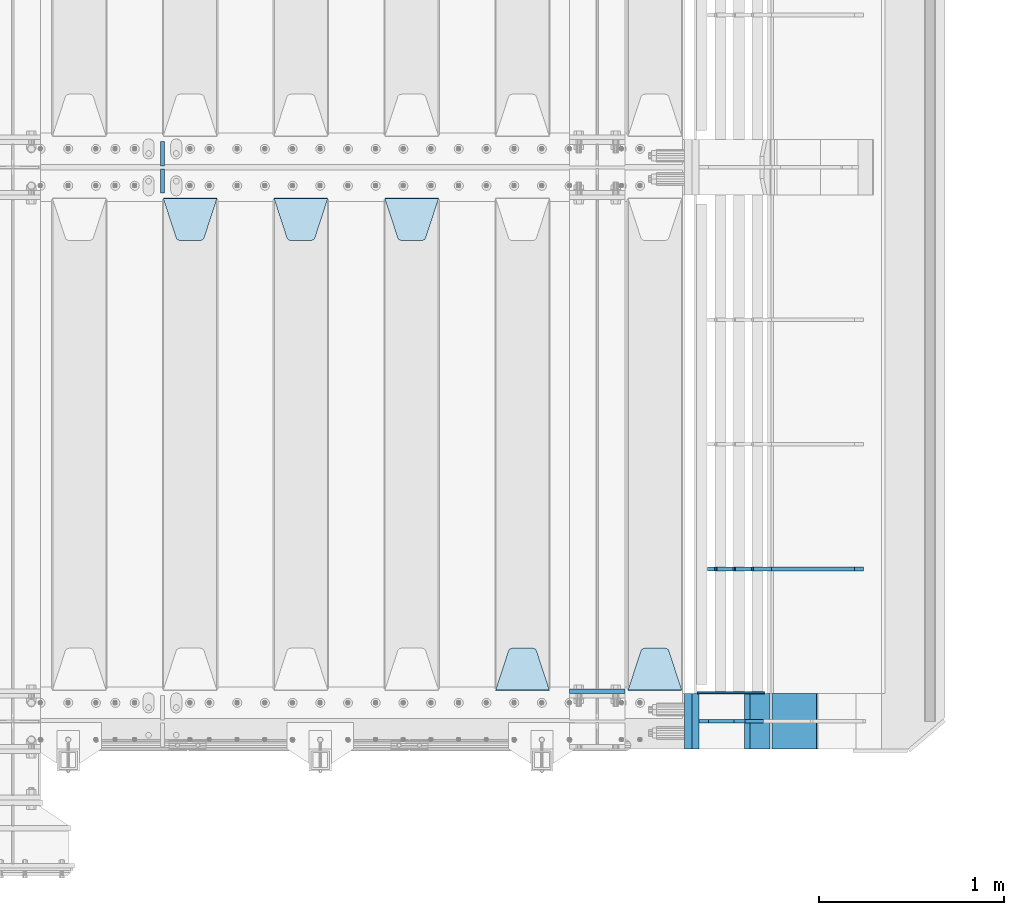
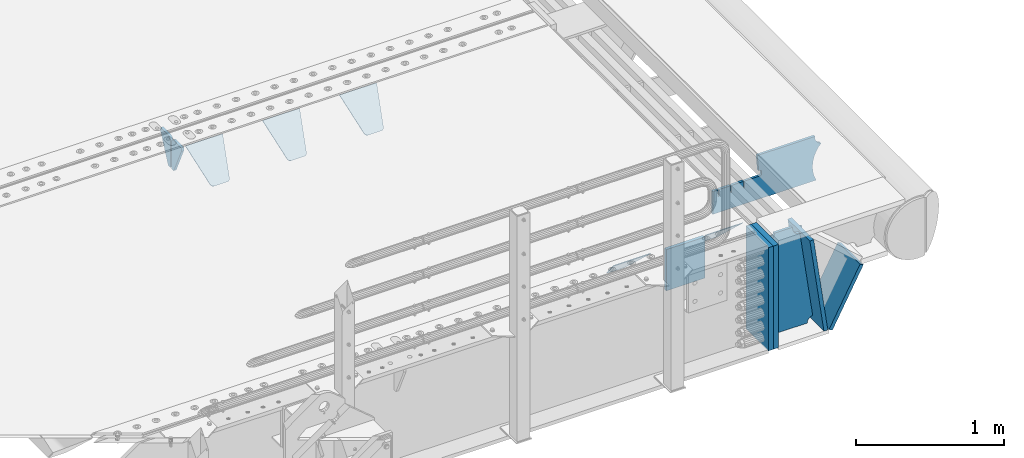
# One storey, part 202 of 240: 15 plates.
"""IFC2X3 building model written with IfcOpenShell, lengths in millimetres."""

from ifc_helpers import new_model, si_unit, frame, origin_with_axes, place, context, subcontext, project, spatial, faceted_brep, material, type_object, element, save


model = new_model("IFC2X3")

# Units and contexts
model_context = context("Model", 3, precision=1e-05, world=origin_with_axes())
body_context = subcontext(model_context, "Body", "Model", "MODEL_VIEW")
ifc_project = project(units=[si_unit("LENGTHUNIT", "METRE", prefix="MILLI"), si_unit("AREAUNIT", "SQUARE_METRE"), si_unit("VOLUMEUNIT", "CUBIC_METRE"), si_unit("MASSUNIT", "GRAM", prefix="KILO"), si_unit("TIMEUNIT", "SECOND"), si_unit("PLANEANGLEUNIT", "RADIAN"), si_unit("SOLIDANGLEUNIT", "STERADIAN"), si_unit("THERMODYNAMICTEMPERATUREUNIT", "DEGREE_CELSIUS"), si_unit("LUMINOUSINTENSITYUNIT", "LUMEN")], contexts=[model_context])

# Site, building, storey
site_placement = place(None, origin_with_axes())
site = spatial("IfcSite", under=ifc_project, at=site_placement, CompositionType="ELEMENT")
building_placement = place(site_placement, origin_with_axes())
building = spatial("IfcBuilding", under=site, at=building_placement, Name="Standard", CompositionType="ELEMENT")
storey_placement = place(building_placement, origin_with_axes())
storey = spatial("IfcBuildingStorey", under=building, at=storey_placement, Name="Undefined", CompositionType="ELEMENT", Elevation=0.0)

# Plates
ifc_material_1 = material(Name="STEEL/S355N")
plate_type_1 = type_object("IfcPlateType", PredefinedType="NOTDEFINED")
plate_1_placement = place(storey_placement, frame((55855.0, 24162.5, -340.000000000044), z_axis=(0.0, 0.0, 1.0), x_axis=(1.0, 0.0, 0.0)))
element("IfcPlate", 1, at=plate_1_placement, inside=storey, type_object=plate_type_1, material=ifc_material_1, context=body_context, shape_type="Brep", body=[
    faceted_brep([(0.0, -12.5, 0.0), (9.31322574615479e-10, -12.5, 340.0), (9.31322574615479e-10, 12.5, 340.0), (0.0, 12.5, 0.0), (300.0, -12.5, 340.0), (300.0, 12.5, 340.0), (300.0, -12.5, 0.0), (300.0, 12.5, 0.0)], [[[0, 1, 2, 3]], [[1, 4, 5, 2]], [[4, 6, 7, 5]], [[6, 0, 3, 7]], [[5, 7, 3, 2]], [[6, 4, 1, 0]]]),
])
plate_type_2 = type_object("IfcPlateType", PredefinedType="NOTDEFINED")
plate_2_placement = place(storey_placement, frame((56462.0, 24168.232233047, -1.76776695296758), z_axis=(0.0, 0.707106781186547, -0.707106781186548), x_axis=(-1.0, 0.0, 0.0)))
element("IfcPlate", 2, at=plate_2_placement, inside=storey, type_object=plate_type_2, material=ifc_material_1, context=body_context, shape_type="Brep", body=[
    faceted_brep([(0.0, -2.5, 0.0), (69.345504679477, -2.50000000000364, 300.171731424827), (69.345504679477, 2.49999999999636, 300.171731424827), (0.0, 2.5, 0.0), (70.927406119954, -2.50000000000364, 304.897442415397), (70.927406119954, 2.49999999999636, 304.897442415397), (73.3818627772271, -2.50000000000728, 309.234538108525), (73.3818627772271, 2.49999999999636, 309.234538108529), (76.6187032999587, -2.50000000000728, 313.023683126099), (76.6187032999587, 2.49999999999636, 313.023683126103), (80.5190132705029, -2.50000000000364, 316.125672595368), (80.5190132705029, 2.49999999999636, 316.125672595368), (84.9395038596849, -2.50000000000364, 318.426546230472), (84.9395038596849, 2.49999999999636, 318.426546230472), (89.7177759439219, -2.5, 319.841774983277), (89.7177759439219, 2.49999999999636, 319.841774983273), (94.6782862926484, -2.50000000000364, 320.319366455074), (94.6782862926484, 2.49999999999636, 320.319366455074), (195.321713707352, -2.50000000000364, 320.319366455074), (195.321713707352, 2.49999999999636, 320.319366455074), (200.282224056078, -2.50000000000364, 319.841774983273), (200.282224056078, 2.49999999999636, 319.841774983273), (205.060496140315, -2.50000000000364, 318.426546230472), (205.060496140315, 2.49999999999636, 318.426546230472), (209.480986729497, -2.50000000000364, 316.125672595368), (209.480986729497, 2.49999999999636, 316.125672595368), (213.381296700041, -2.50000000000728, 313.023683126099), (213.381296700041, 2.49999999999272, 313.023683126099), (216.618137222766, -2.50000000000364, 309.234538108522), (216.618137222766, 2.49999999999636, 309.234538108522), (219.072593880039, -2.50000000000364, 304.897442415397), (219.072593880039, 2.49999999999636, 304.897442415397), (220.654495320523, -2.50000000000364, 300.171731424827), (220.654495320523, 2.49999999999636, 300.171731424827), (290.0, -2.50000000000364, -3.63797880709171e-12), (290.0, 2.49999999999636, -3.63797880709171e-12)], [[[0, 1, 2, 3]], [[1, 4, 5, 2]], [[4, 6, 7, 5]], [[6, 8, 9, 7]], [[8, 10, 11, 9]], [[10, 12, 13, 11]], [[12, 14, 15, 13]], [[14, 16, 17, 15]], [[16, 18, 19, 17]], [[18, 20, 21, 19]], [[20, 22, 23, 21]], [[22, 24, 25, 23]], [[24, 26, 27, 25]], [[26, 28, 29, 27]], [[28, 30, 31, 29]], [[30, 32, 33, 31]], [[32, 34, 35, 33]], [[34, 0, 3, 35]], [[5, 7, 9, 11, 13, 15, 17, 19, 21, 23, 25, 27, 29, 31, 33, 35, 3, 2]], [[34, 32, 30, 28, 26, 24, 22, 20, 18, 16, 14, 12, 10, 8, 6, 4, 1, 0]]]),
])
plate_3_placement = place(storey_placement, frame((55745.0, 24168.232233047, -1.76776695296758), z_axis=(0.0, 0.707106781186547, -0.707106781186548), x_axis=(-1.0, 0.0, 0.0)))
element("IfcPlate", 3, at=plate_3_placement, inside=storey, type_object=plate_type_2, material=ifc_material_1, context=body_context, shape_type="Brep", body=[
    faceted_brep([(0.0, -2.5, 0.0), (69.345504679477, -2.50000000000364, 300.171731424827), (69.345504679477, 2.49999999999636, 300.171731424827), (0.0, 2.5, 0.0), (70.927406119954, -2.50000000000364, 304.897442415397), (70.927406119954, 2.49999999999636, 304.897442415397), (73.3818627772271, -2.50000000000728, 309.234538108525), (73.3818627772271, 2.49999999999636, 309.234538108529), (76.6187032999587, -2.50000000000728, 313.023683126099), (76.6187032999587, 2.49999999999636, 313.023683126103), (80.5190132705029, -2.50000000000364, 316.125672595368), (80.5190132705029, 2.49999999999636, 316.125672595368), (84.9395038596849, -2.50000000000364, 318.426546230472), (84.9395038596849, 2.49999999999636, 318.426546230472), (89.7177759439219, -2.5, 319.841774983277), (89.7177759439219, 2.49999999999636, 319.841774983273), (94.6782862926484, -2.50000000000364, 320.319366455074), (94.6782862926484, 2.49999999999636, 320.319366455074), (195.321713707352, -2.50000000000364, 320.319366455074), (195.321713707352, 2.49999999999636, 320.319366455074), (200.282224056078, -2.50000000000364, 319.841774983273), (200.282224056078, 2.49999999999636, 319.841774983273), (205.060496140315, -2.50000000000364, 318.426546230472), (205.060496140315, 2.49999999999636, 318.426546230472), (209.480986729497, -2.50000000000364, 316.125672595368), (209.480986729497, 2.49999999999636, 316.125672595368), (213.381296700041, -2.50000000000728, 313.023683126099), (213.381296700041, 2.49999999999272, 313.023683126099), (216.618137222766, -2.50000000000364, 309.234538108522), (216.618137222766, 2.49999999999636, 309.234538108522), (219.072593880039, -2.50000000000364, 304.897442415397), (219.072593880039, 2.49999999999636, 304.897442415397), (220.654495320523, -2.50000000000364, 300.171731424827), (220.654495320523, 2.49999999999636, 300.171731424827), (290.0, -2.50000000000364, -3.63797880709171e-12), (290.0, 2.49999999999636, -3.63797880709171e-12)], [[[0, 1, 2, 3]], [[1, 4, 5, 2]], [[4, 6, 7, 5]], [[6, 8, 9, 7]], [[8, 10, 11, 9]], [[10, 12, 13, 11]], [[12, 14, 15, 13]], [[14, 16, 17, 15]], [[16, 18, 19, 17]], [[18, 20, 21, 19]], [[20, 22, 23, 21]], [[22, 24, 25, 23]], [[24, 26, 27, 25]], [[26, 28, 29, 27]], [[28, 30, 31, 29]], [[30, 32, 33, 31]], [[32, 34, 35, 33]], [[34, 0, 3, 35]], [[5, 7, 9, 11, 13, 15, 17, 19, 21, 23, 25, 27, 29, 31, 33, 35, 3, 2]], [[34, 32, 30, 28, 26, 24, 22, 20, 18, 16, 14, 12, 10, 8, 6, 4, 1, 0]]]),
])
plate_4_placement = place(storey_placement, frame((54855.0, 26831.767766956, -1.76776695296758), z_axis=(0.0, -0.707106781186547, -0.707106781186548), x_axis=(1.0, 0.0, 0.0)))
element("IfcPlate", 4, at=plate_4_placement, inside=storey, type_object=plate_type_2, material=ifc_material_1, context=body_context, shape_type="Brep", body=[
    faceted_brep([(0.0, -2.5, 0.0), (69.345504679477, -2.50000000000364, 300.171731424827), (69.345504679477, 2.49999999999636, 300.171731424827), (0.0, 2.5, 0.0), (70.927406119954, -2.50000000000364, 304.897442415397), (70.927406119954, 2.49999999999636, 304.897442415397), (73.3818627772271, -2.50000000000728, 309.234538108525), (73.3818627772271, 2.49999999999636, 309.234538108529), (76.6187032999587, -2.50000000000728, 313.023683126099), (76.6187032999587, 2.49999999999636, 313.023683126103), (80.5190132705029, -2.50000000000364, 316.125672595368), (80.5190132705029, 2.49999999999636, 316.125672595368), (84.9395038596849, -2.50000000000364, 318.426546230472), (84.9395038596849, 2.49999999999636, 318.426546230472), (89.7177759439219, -2.5, 319.841774983277), (89.7177759439219, 2.49999999999636, 319.841774983273), (94.6782862926484, -2.50000000000364, 320.319366455074), (94.6782862926484, 2.49999999999636, 320.319366455074), (195.321713707352, -2.50000000000364, 320.319366455074), (195.321713707352, 2.49999999999636, 320.319366455074), (200.282224056078, -2.50000000000364, 319.841774983273), (200.282224056078, 2.49999999999636, 319.841774983273), (205.060496140315, -2.50000000000364, 318.426546230472), (205.060496140315, 2.49999999999636, 318.426546230472), (209.480986729497, -2.50000000000364, 316.125672595368), (209.480986729497, 2.49999999999636, 316.125672595368), (213.381296700041, -2.50000000000728, 313.023683126099), (213.381296700041, 2.49999999999272, 313.023683126099), (216.618137222766, -2.50000000000364, 309.234538108522), (216.618137222766, 2.49999999999636, 309.234538108522), (219.072593880039, -2.50000000000364, 304.897442415397), (219.072593880039, 2.49999999999636, 304.897442415397), (220.654495320523, -2.50000000000364, 300.171731424827), (220.654495320523, 2.49999999999636, 300.171731424827), (290.0, -2.50000000000364, -3.63797880709171e-12), (290.0, 2.49999999999636, -3.63797880709171e-12)], [[[0, 1, 2, 3]], [[1, 4, 5, 2]], [[4, 6, 7, 5]], [[6, 8, 9, 7]], [[8, 10, 11, 9]], [[10, 12, 13, 11]], [[12, 14, 15, 13]], [[14, 16, 17, 15]], [[16, 18, 19, 17]], [[18, 20, 21, 19]], [[20, 22, 23, 21]], [[22, 24, 25, 23]], [[24, 26, 27, 25]], [[26, 28, 29, 27]], [[28, 30, 31, 29]], [[30, 32, 33, 31]], [[32, 34, 35, 33]], [[34, 0, 3, 35]], [[5, 7, 9, 11, 13, 15, 17, 19, 21, 23, 25, 27, 29, 31, 33, 35, 3, 2]], [[34, 32, 30, 28, 26, 24, 22, 20, 18, 16, 14, 12, 10, 8, 6, 4, 1, 0]]]),
])
plate_5_placement = place(storey_placement, frame((54255.0, 26831.767766956, -1.76776695296758), z_axis=(0.0, -0.707106781186547, -0.707106781186548), x_axis=(1.0, 0.0, 0.0)))
element("IfcPlate", 5, at=plate_5_placement, inside=storey, type_object=plate_type_2, material=ifc_material_1, context=body_context, shape_type="Brep", body=[
    faceted_brep([(0.0, -2.5, 0.0), (69.345504679477, -2.50000000000364, 300.171731424827), (69.345504679477, 2.49999999999636, 300.171731424827), (0.0, 2.5, 0.0), (70.927406119954, -2.50000000000364, 304.897442415397), (70.927406119954, 2.49999999999636, 304.897442415397), (73.3818627772271, -2.50000000000728, 309.234538108525), (73.3818627772271, 2.49999999999636, 309.234538108529), (76.6187032999587, -2.50000000000728, 313.023683126099), (76.6187032999587, 2.49999999999636, 313.023683126103), (80.5190132705029, -2.50000000000364, 316.125672595368), (80.5190132705029, 2.49999999999636, 316.125672595368), (84.9395038596849, -2.50000000000364, 318.426546230472), (84.9395038596849, 2.49999999999636, 318.426546230472), (89.7177759439219, -2.5, 319.841774983277), (89.7177759439219, 2.49999999999636, 319.841774983273), (94.6782862926484, -2.50000000000364, 320.319366455074), (94.6782862926484, 2.49999999999636, 320.319366455074), (195.321713707352, -2.50000000000364, 320.319366455074), (195.321713707352, 2.49999999999636, 320.319366455074), (200.282224056078, -2.50000000000364, 319.841774983273), (200.282224056078, 2.49999999999636, 319.841774983273), (205.060496140315, -2.50000000000364, 318.426546230472), (205.060496140315, 2.49999999999636, 318.426546230472), (209.480986729497, -2.50000000000364, 316.125672595368), (209.480986729497, 2.49999999999636, 316.125672595368), (213.381296700041, -2.50000000000728, 313.023683126099), (213.381296700041, 2.49999999999272, 313.023683126099), (216.618137222766, -2.50000000000364, 309.234538108522), (216.618137222766, 2.49999999999636, 309.234538108522), (219.072593880039, -2.50000000000364, 304.897442415397), (219.072593880039, 2.49999999999636, 304.897442415397), (220.654495320523, -2.50000000000364, 300.171731424827), (220.654495320523, 2.49999999999636, 300.171731424827), (290.0, -2.50000000000364, -3.63797880709171e-12), (290.0, 2.49999999999636, -3.63797880709171e-12)], [[[0, 1, 2, 3]], [[1, 4, 5, 2]], [[4, 6, 7, 5]], [[6, 8, 9, 7]], [[8, 10, 11, 9]], [[10, 12, 13, 11]], [[12, 14, 15, 13]], [[14, 16, 17, 15]], [[16, 18, 19, 17]], [[18, 20, 21, 19]], [[20, 22, 23, 21]], [[22, 24, 25, 23]], [[24, 26, 27, 25]], [[26, 28, 29, 27]], [[28, 30, 31, 29]], [[30, 32, 33, 31]], [[32, 34, 35, 33]], [[34, 0, 3, 35]], [[5, 7, 9, 11, 13, 15, 17, 19, 21, 23, 25, 27, 29, 31, 33, 35, 3, 2]], [[34, 32, 30, 28, 26, 24, 22, 20, 18, 16, 14, 12, 10, 8, 6, 4, 1, 0]]]),
])
plate_6_placement = place(storey_placement, frame((53655.0, 26831.767766956, -1.76776695296758), z_axis=(0.0, -0.707106781186547, -0.707106781186548), x_axis=(1.0, 0.0, 0.0)))
element("IfcPlate", 6, at=plate_6_placement, inside=storey, type_object=plate_type_2, material=ifc_material_1, context=body_context, shape_type="Brep", body=[
    faceted_brep([(0.0, -2.5, 0.0), (69.345504679477, -2.50000000000364, 300.171731424827), (69.345504679477, 2.49999999999636, 300.171731424827), (0.0, 2.5, 0.0), (70.927406119954, -2.50000000000364, 304.897442415397), (70.927406119954, 2.49999999999636, 304.897442415397), (73.3818627772271, -2.50000000000728, 309.234538108525), (73.3818627772271, 2.49999999999636, 309.234538108529), (76.6187032999587, -2.50000000000728, 313.023683126099), (76.6187032999587, 2.49999999999636, 313.023683126103), (80.5190132705029, -2.50000000000364, 316.125672595368), (80.5190132705029, 2.49999999999636, 316.125672595368), (84.9395038596849, -2.50000000000364, 318.426546230472), (84.9395038596849, 2.49999999999636, 318.426546230472), (89.7177759439219, -2.5, 319.841774983277), (89.7177759439219, 2.49999999999636, 319.841774983273), (94.6782862926484, -2.50000000000364, 320.319366455074), (94.6782862926484, 2.49999999999636, 320.319366455074), (195.321713707352, -2.50000000000364, 320.319366455074), (195.321713707352, 2.49999999999636, 320.319366455074), (200.282224056078, -2.50000000000364, 319.841774983273), (200.282224056078, 2.49999999999636, 319.841774983273), (205.060496140315, -2.50000000000364, 318.426546230472), (205.060496140315, 2.49999999999636, 318.426546230472), (209.480986729497, -2.50000000000364, 316.125672595368), (209.480986729497, 2.49999999999636, 316.125672595368), (213.381296700041, -2.50000000000728, 313.023683126099), (213.381296700041, 2.49999999999272, 313.023683126099), (216.618137222766, -2.50000000000364, 309.234538108522), (216.618137222766, 2.49999999999636, 309.234538108522), (219.072593880039, -2.50000000000364, 304.897442415397), (219.072593880039, 2.49999999999636, 304.897442415397), (220.654495320523, -2.50000000000364, 300.171731424827), (220.654495320523, 2.49999999999636, 300.171731424827), (290.0, -2.50000000000364, -3.63797880709171e-12), (290.0, 2.49999999999636, -3.63797880709171e-12)], [[[0, 1, 2, 3]], [[1, 4, 5, 2]], [[4, 6, 7, 5]], [[6, 8, 9, 7]], [[8, 10, 11, 9]], [[10, 12, 13, 11]], [[12, 14, 15, 13]], [[14, 16, 17, 15]], [[16, 18, 19, 17]], [[18, 20, 21, 19]], [[20, 22, 23, 21]], [[22, 24, 25, 23]], [[24, 26, 27, 25]], [[26, 28, 29, 27]], [[28, 30, 31, 29]], [[30, 32, 33, 31]], [[32, 34, 35, 33]], [[34, 0, 3, 35]], [[5, 7, 9, 11, 13, 15, 17, 19, 21, 23, 25, 27, 29, 31, 33, 35, 3, 2]], [[34, 32, 30, 28, 26, 24, 22, 20, 18, 16, 14, 12, 10, 8, 6, 4, 1, 0]]]),
])
ifc_material_2 = material()
plate_type_3 = type_object("IfcPlateType", PredefinedType="NOTDEFINED")
for number, where, z_axis, x_axis in (
    (7, (56536.9988298907, 24150.0, -869.999999999366), (0.0, 0.0, 1.0), (0.0, -1.0, 0.0)),
    (8, (56497.0, 24150.0, -870.0), (0.0, 0.0, 1.0), (0.0, -1.0, 0.0)),
):
    element("IfcPlate", number, at=place(storey_placement, frame(where, z_axis=z_axis, x_axis=x_axis)), inside=storey, type_object=plate_type_3, material=ifc_material_2, context=body_context, shape_type="Brep", body=[
        faceted_brep([(0.0, -20.0, 0.0), (0.0, -20.0, 850.0), (0.0, 20.0, 850.0), (0.0, 20.0, 0.0), (300.0, -20.0, 850.0), (300.0, 20.0, 850.0), (300.0, -20.0, -1.81898940354586e-12), (300.0, 20.0, -1.81898940354586e-12)], [[[0, 1, 2, 3]], [[1, 4, 5, 2]], [[4, 6, 7, 5]], [[6, 0, 3, 7]], [[5, 7, 3, 2]], [[6, 4, 1, 0]]]),
    ])
plate_type_4 = type_object("IfcPlateType", PredefinedType="NOTDEFINED")
for number, where, z_axis, x_axis in (
    (9, (53650.0, 27140.0, -30.0), (0.0, 0.0, -1.0), (0.0, -1.0, 0.0)),
    (10, (53650.0, 26860.0, -30.0), (0.0, 0.0, -1.0), (0.0, 1.0, 0.0)),
):
    element("IfcPlate", number, at=place(storey_placement, frame(where, z_axis=z_axis, x_axis=x_axis)), inside=storey, type_object=plate_type_4, material=ifc_material_1, context=body_context, shape_type="Brep", body=[
        faceted_brep([(0.0, -10.0, 0.0), (0.0, -10.0, 30.0), (0.0, 10.0, 30.0), (0.0, 10.0, 0.0), (102.0, -10.0, 250.0), (102.0, 10.0, 250.0), (132.0, -10.0, 250.0), (132.0, 10.0, 250.0), (132.0, -10.0, 30.0), (132.0, 10.0, 30.0), (131.544232590368, -10.0, 24.790554669992), (131.544232590368, 10.0, 24.790554669992), (130.190778623579, -10.0, 19.7393957002299), (130.190778623579, 10.0, 19.7393957002299), (127.980762113533, -10.0, 15.0), (127.980762113533, 10.0, 15.0), (124.98133329357, -10.0, 10.7163717094038), (124.98133329357, 10.0, 10.7163717094038), (121.283628290596, -10.0, 7.01866670643062), (121.283628290596, 10.0, 7.01866670643062), (117.0, -10.0, 4.01923788646684), (117.0, 10.0, 4.01923788646684), (112.260604299769, -10.0, 1.80922137642278), (112.260604299769, 10.0, 1.80922137642278), (107.209445330009, -10.0, 0.455767409633722), (107.209445330009, 10.0, 0.455767409633722), (102.0, -10.0, 0.0), (102.0, 10.0, 0.0)], [[[0, 1, 2, 3]], [[1, 4, 5, 2]], [[4, 6, 7, 5]], [[6, 8, 9, 7]], [[8, 10, 11, 9]], [[10, 12, 13, 11]], [[12, 14, 15, 13]], [[14, 16, 17, 15]], [[16, 18, 19, 17]], [[18, 20, 21, 19]], [[20, 22, 23, 21]], [[22, 24, 25, 23]], [[24, 26, 27, 25]], [[26, 0, 3, 27]], [[5, 7, 9, 11, 13, 15, 17, 19, 21, 23, 25, 27, 3, 2]], [[26, 24, 22, 20, 18, 16, 14, 12, 10, 8, 6, 4, 1, 0]]]),
    ])
plate_type_5 = type_object("IfcPlateType", PredefinedType="NOTDEFINED")
plate_7_placement = place(storey_placement, frame((57442.9182339676, 24824.9992828369, -374.002067436518), z_axis=(0.0, 0.0, 1.0), x_axis=(-1.0, 0.0, 0.0)))
element("IfcPlate", 11, at=plate_7_placement, inside=storey, type_object=plate_type_5, material=ifc_material_1, context=body_context, shape_type="Brep", body=[
    faceted_brep([(801.919404066546, -10.0, 188.0), (801.919404066546, 10.0, 188.0), (801.919404066546, 10.0, 132.002067436952), (801.919404066546, -10.0, 132.002067436952), (793.919404066546, 10.0, 132.002067436952), (793.919404066546, -10.0, 132.002067436952), (793.919404066546, 10.0, 180.002067436952), (793.919404066546, -10.0, 180.002067436952), (793.52785619691, 10.0, 182.474203391951), (793.52785619691, -10.0, 182.474203391951), (792.391540021548, 10.0, 184.704349455291), (792.391540021548, -10.0, 184.704349455291), (790.621686084887, 10.0, 186.474203391951), (790.621686084887, -10.0, 186.474203391951), (788.391540021548, 10.0, 187.610519567313), (788.391540021548, -10.0, 187.610519567313), (785.919404066546, -10.0, 188.002067436952), (785.919404066546, 10.0, 188.0), (841.0, -10.0, 188.0), (841.0, -10.0, 0.0), (841.0, 10.0, 0.0), (841.0, 10.0, 188.0), (33.3619566735943, -10.0, 0.0), (33.3619566735943, 10.0, 0.0), (36.2350612208102, -10.0, 4.68848050267013), (36.2350612208102, 10.0, 4.68848050267013), (51.4877592159319, -10.0, 41.5117508652784), (51.4877592159319, 10.0, 41.5117508652784), (60.7922425881334, -10.0, 80.2677133162964), (60.7922425881334, 10.0, 80.2677133162964), (63.9194040769653, -10.0, 120.002067436515), (63.9194040769653, 10.0, 120.002067436515), (60.7922425881334, -10.0, 159.736421556734), (60.7922425881334, 10.0, 159.736421556734), (51.4877592159319, -10.0, 198.492384007752), (51.4877592159319, 10.0, 198.492384007752), (36.2350612208102, -10.0, 235.31565437036), (36.2350612208102, 10.0, 235.31565437036), (15.4097206482038, -10.0, 269.299521518803), (15.4097206482038, 10.0, 269.299521518803), (-3.35474438100209, -10.0, 291.269887256574), (-3.35474438100209, 10.0, 291.269887256574), (-2.36881039375294, -10.0000000000036, 291.426043859339), (-2.36881039375294, 10.0, 291.426043859339), (17.1449676604752, -10.0000000000036, 301.368810393754), (17.1449676604752, 10.0, 301.368810393754), (32.6311896062471, -10.0000000000036, 316.855032339527), (32.6311896062471, 10.0, 316.855032339527), (42.573956140659, -10.0000000000036, 336.368810393754), (42.573956140659, 10.0, 336.368810393754), (46.0, -10.0000000000036, 358.0), (46.0, 10.0, 358.0), (45.0495205499246, -10.0, 364.001091067617), (45.0495205499246, 10.0, 364.001091067617), (495.040008544922, -10.0, 364.010009765625), (495.040008544922, 10.0, 364.010009765625), (483.600036621094, -10.0, 233.759994506836), (483.600036621094, 10.0, 233.759994506836), (472.0, -10.0, 233.759994506836), (472.0, 10.0, 233.759994506836), (468.909830056247, -10.0, 233.270559669787), (468.909830056247, 10.0, 233.270559669787), (466.122147477072, -10.0, 231.850164450585), (466.122147477072, 10.0, 231.850164450585), (463.909830056247, -10.0, 229.637847029761), (463.909830056247, 10.0, 229.637847029761), (462.489434837051, -10.0, 226.850164450585), (462.489434837051, 10.0, 226.850164450585), (462.0, -10.0, 223.759994506836), (462.0, 10.0, 223.759994506836), (462.0, -10.0, 198.0), (462.0, 10.0, 198.0), (462.489434837051, -10.0, 194.909830056251), (462.489434837051, 10.0, 194.909830056251), (463.909830056247, -10.0, 192.122147477075), (463.909830056247, 10.0, 192.122147477075), (466.122147477072, -10.0, 189.909830056251), (466.122147477072, 10.0, 189.909830056251), (468.909830056247, -10.0, 188.489434837048), (468.909830056247, 10.0, 188.489434837048), (472.0, -10.0, 188.0), (472.0, 10.0, 188.0), (585.919404066546, -10.0, 188.002067436952), (585.919404066546, 10.0, 188.0), (588.391540021548, -9.99999999999636, 187.610519567313), (588.391540021548, 10.0, 187.610519567313), (590.621686084887, -9.99999999999636, 186.474203391951), (590.621686084887, 10.0, 186.474203391951), (592.391540021548, -9.99999999999636, 184.704349455291), (592.391540021548, 10.0, 184.704349455291), (593.52785619691, -9.99999999999636, 182.474203391951), (593.52785619691, 10.0, 182.474203391951), (593.919404066546, -9.99999999999636, 180.002067436952), (593.919404066546, 10.0, 180.002067436952), (593.919404066546, -9.99999999999636, 132.002067436952), (593.919404066546, 10.0, 132.002067436952), (601.919404066546, -9.99999999999636, 132.002067436952), (601.919404066546, 10.0, 132.002067436952), (601.919404066546, -10.0, 188.0), (601.919404066546, 10.0, 188.0), (685.919404066546, -10.0, 188.002067436952), (685.919404066546, 10.0, 188.0), (688.391540021548, -10.0, 187.610519567313), (688.391540021548, 10.0, 187.610519567313), (690.621686084887, -10.0, 186.474203391951), (690.621686084887, 10.0, 186.474203391951), (692.391540021548, -10.0, 184.704349455291), (692.391540021548, 10.0, 184.704349455291), (693.52785619691, -10.0, 182.474203391951), (693.52785619691, 10.0, 182.474203391951), (693.919404066546, -10.0, 180.002067436952), (693.919404066546, 10.0, 180.002067436952), (693.919404066546, -10.0, 132.002067436952), (693.919404066546, 10.0000000000036, 132.002067436952), (701.919404066546, -10.0, 132.002067436952), (701.919404066546, 10.0000000000036, 132.002067436952), (701.919404066546, -10.0, 188.0), (701.919404066546, 10.0, 188.0)], [[[0, 1, 2, 3]], [[3, 2, 4, 5]], [[5, 4, 6, 7]], [[7, 6, 8, 9]], [[9, 8, 10, 11]], [[11, 10, 12, 13]], [[13, 12, 14, 15]], [[16, 15, 14, 17]], [[18, 19, 20, 21]], [[20, 19, 22, 23]], [[22, 24, 25, 23]], [[26, 27, 25, 24]], [[28, 29, 27, 26]], [[30, 31, 29, 28]], [[32, 33, 31, 30]], [[34, 35, 33, 32]], [[36, 37, 35, 34]], [[38, 39, 37, 36]], [[39, 38, 40, 41]], [[40, 42, 43, 41]], [[44, 45, 43, 42]], [[46, 47, 45, 44]], [[48, 49, 47, 46]], [[50, 51, 49, 48]], [[52, 53, 51, 50]], [[54, 55, 53, 52]], [[54, 56, 57, 55]], [[56, 58, 59, 57]], [[58, 60, 61, 59]], [[60, 62, 63, 61]], [[62, 64, 65, 63]], [[64, 66, 67, 65]], [[66, 68, 69, 67]], [[68, 70, 71, 69]], [[70, 72, 73, 71]], [[72, 74, 75, 73]], [[74, 76, 77, 75]], [[76, 78, 79, 77]], [[78, 80, 81, 79]], [[81, 80, 82, 83]], [[82, 84, 85, 83]], [[86, 87, 85, 84]], [[88, 89, 87, 86]], [[90, 91, 89, 88]], [[92, 93, 91, 90]], [[94, 95, 93, 92]], [[96, 97, 95, 94]], [[98, 99, 97, 96]], [[99, 98, 100, 101]], [[100, 102, 103, 101]], [[104, 105, 103, 102]], [[106, 107, 105, 104]], [[108, 109, 107, 106]], [[110, 111, 109, 108]], [[112, 113, 111, 110]], [[114, 115, 113, 112]], [[116, 117, 115, 114]], [[117, 116, 16, 17]], [[12, 10, 8, 6, 4, 2, 1, 21, 20, 23, 25, 27, 29, 31, 33, 35, 37, 39, 41, 43, 45, 47, 49, 51, 53, 55, 57, 59, 61, 63, 65, 67, 69, 71, 73, 75, 77, 79, 81, 83, 85, 87, 89, 91, 93, 95, 97, 99, 101, 103, 105, 107, 109, 111, 113, 115, 117, 17, 14]], [[18, 21, 1, 0]], [[116, 114, 112, 110, 108, 106, 104, 102, 100, 98, 96, 94, 92, 90, 88, 86, 84, 82, 80, 78, 76, 74, 72, 70, 68, 66, 64, 62, 60, 58, 56, 54, 52, 50, 48, 46, 44, 42, 40, 38, 36, 34, 32, 30, 28, 26, 24, 22, 19, 18, 0, 3, 5, 7, 9, 11, 13, 15, 16]]]),
])
plate_type_6 = type_object("IfcPlateType", PredefinedType="NOTDEFINED")
plate_8_placement = place(storey_placement, frame((56926.1480677228, 24150.000000001, -862.083788726706), z_axis=(-0.139173011053008, 0.0, 0.990268081377179), x_axis=(0.0, -1.0, 0.0)))
element("IfcPlate", 12, at=plate_8_placement, inside=storey, type_object=plate_type_6, material=ifc_material_1, context=body_context, shape_type="Brep", body=[
    faceted_brep([(1.00408215075731e-09, 14.9994702460463, -0.00376939772468177), (300.0, 15.0, 0.0), (300.0, -15.0, 4.21237841381662), (0.0, -15.0, 4.21237841381662), (0.0, -15.0, 792.000000000001), (300.0, -15.0, 792.000000000001), (300.0, 14.9999999999927, 792.000000000001), (0.0, 14.9999999999927, 792.000000000001)], [[[0, 1, 2, 3]], [[4, 5, 6, 7]], [[4, 7, 0, 3]], [[5, 4, 3, 2]], [[6, 5, 2, 1]], [[7, 6, 1, 0]]]),
])
plate_9_placement = place(storey_placement, frame((56963.2468009574, 24150.000000001, -867.038754737463), z_axis=(0.469471552246179, 0.0, 0.882947598462991), x_axis=(0.0, -1.0, 0.0)))
element("IfcPlate", 13, at=plate_9_placement, inside=storey, type_object=plate_type_6, material=ifc_material_1, context=body_context, shape_type="Brep", body=[
    faceted_brep([(0.0, -15.0, 0.0), (0.0, -15.0, 514.999999999996), (0.0, 15.0, 515.0), (0.0, 15.0, 0.0), (300.0, -15.0, 514.999999999996), (300.0, 15.0, 515.0), (300.0, -15.0, 0.0), (300.0, 15.0, 0.0)], [[[0, 1, 2, 3]], [[1, 4, 5, 2]], [[4, 6, 7, 5]], [[6, 0, 3, 7]], [[5, 7, 3, 2]], [[6, 4, 1, 0]]]),
])
plate_type_7 = type_object("IfcPlateType", PredefinedType="NOTDEFINED")
plate_10_placement = place(storey_placement, frame((56795.9988298891, 24000.0, -30.0000000026171), z_axis=(0.0, 0.0, -1.0), x_axis=(-1.0, 0.0, 0.0)))
element("IfcPlate", 14, at=plate_10_placement, inside=storey, type_object=plate_type_7, material=ifc_material_1, context=body_context, shape_type="Brep", body=[
    faceted_brep([(-9.00602409638668, -10.0, 65.0), (-108.137843376921, -10.0, 780.473130459514), (-108.137843376921, 10.0, 780.473130459514), (-9.00602409638668, 10.0, 65.0), (-94.4157884488377, -10.0, 784.433672138112), (-94.4157884488377, 10.0, 784.433672138112), (-82.3732461236723, -10.0, 792.112074067144), (-82.3732461236723, 10.0, 792.112074067144), (-72.9927947992401, -10.0, 802.881837982249), (-72.9927947992401, 10.0, 802.881837982249), (-67.0398068183713, -10.0, 815.864234368775), (-67.0398068183713, 10.0, 815.864234368775), (-65.0, -10.0, 830.0), (-65.0, 10.0, 830.0), (189.0, -10.0, 830.0), (189.0, 10.0, 830.0), (191.447174185239, -10.0, 814.549150281253), (191.447174185239, 10.0, 814.549150281253), (198.549150281251, -10.0, 800.610737385376), (198.549150281251, 10.0, 800.610737385376), (209.610737385374, -10.0, 789.549150281253), (209.610737385374, 10.0, 789.549150281253), (223.549150281251, -10.0, 782.447174185242), (223.549150281251, 10.0, 782.447174185242), (239.0, -10.0, 780.0), (239.0, 10.0, 780.0), (239.0, -10.0, 50.0), (239.0, 10.0, 50.0), (223.549150281251, -10.0, 47.5528258147577), (223.549150281251, 10.0, 47.5528258147577), (209.610737385374, -10.0, 40.4508497187474), (209.610737385374, 10.0, 40.4508497187474), (198.549150281251, -10.0, 29.3892626146237), (198.549150281251, 10.0, 29.3892626146237), (191.447174185239, -10.0, 15.4508497187474), (191.447174185239, 10.0, 15.4508497187474), (189.0, -10.0, 0.0), (189.0, 10.0, 0.0), (50.4776502774184, -10.0, 0.0), (50.4776502774184, 10.0, 0.0), (47.3830020671812, -10.0, 22.3352870825933), (47.3830020671812, 10.0, 22.3352870825933), (42.8384615202813, -10.0, 37.3040735979326), (42.8384615202813, 10.0, 37.3040735979326), (33.8907372011745, -10.0, 50.1358952937587), (33.8907372011745, 10.0, 50.1358952937587), (21.415694708674, -10.0, 59.5746840579253), (21.415694708674, 10.0, 59.5746840579253), (6.63447812067898, -10.0, 64.6965054822873), (6.63447812067898, 10.0, 64.6965054822873)], [[[0, 1, 2, 3]], [[1, 4, 5, 2]], [[4, 6, 7, 5]], [[6, 8, 9, 7]], [[8, 10, 11, 9]], [[10, 12, 13, 11]], [[12, 14, 15, 13]], [[14, 16, 17, 15]], [[16, 18, 19, 17]], [[18, 20, 21, 19]], [[20, 22, 23, 21]], [[22, 24, 25, 23]], [[24, 26, 27, 25]], [[26, 28, 29, 27]], [[28, 30, 31, 29]], [[30, 32, 33, 31]], [[32, 34, 35, 33]], [[34, 36, 37, 35]], [[36, 38, 39, 37]], [[38, 40, 41, 39]], [[40, 42, 43, 41]], [[42, 44, 45, 43]], [[44, 46, 47, 45]], [[46, 48, 49, 47]], [[48, 0, 3, 49]], [[5, 7, 9, 11, 13, 15, 17, 19, 21, 23, 25, 27, 29, 31, 33, 35, 37, 39, 41, 43, 45, 47, 49, 3, 2]], [[48, 46, 44, 42, 40, 38, 36, 34, 32, 30, 28, 26, 24, 22, 20, 18, 16, 14, 12, 10, 8, 6, 4, 1, 0]]]),
])
plate_type_8 = type_object("IfcPlateType", PredefinedType="NOTDEFINED")
plate_11_placement = place(storey_placement, frame((56911.998829901, 24155.0, -249.999999999564), z_axis=(-1.0, 0.0, 0.0), x_axis=(0.0, 0.0, 1.0)))
element("IfcPlate", 15, at=plate_11_placement, inside=storey, type_object=plate_type_8, material=ifc_material_1, context=body_context, shape_type="Brep", body=[
    faceted_brep([(0.0, -5.0, 0.0), (0.0, -5.0, 365.0), (0.0, 5.0, 365.0), (0.0, 5.0, 0.0), (80.0, -5.0, 365.0), (80.0, 5.0, 365.0), (80.0, -5.0, 0.0), (80.0, 5.0, 0.0)], [[[0, 1, 2, 3]], [[1, 4, 5, 2]], [[4, 6, 7, 5]], [[6, 0, 3, 7]], [[5, 7, 3, 2]], [[6, 4, 1, 0]]]),
])

save(model, "model.ifc")
